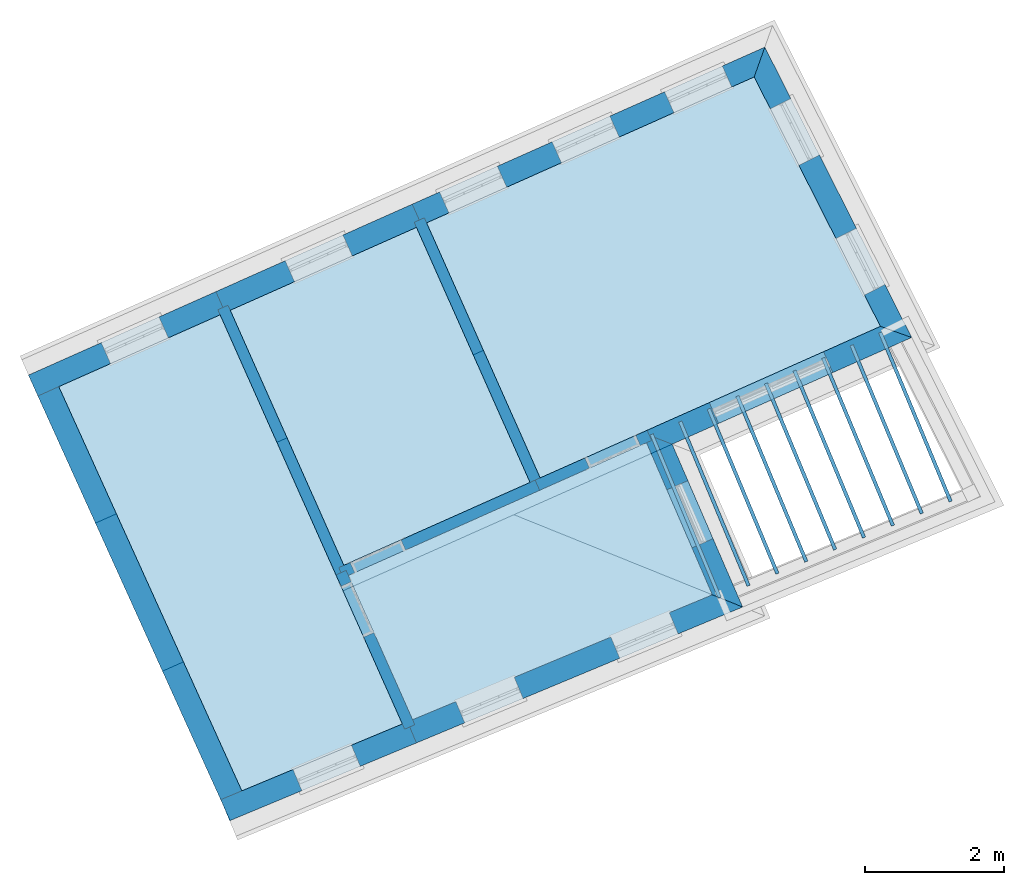
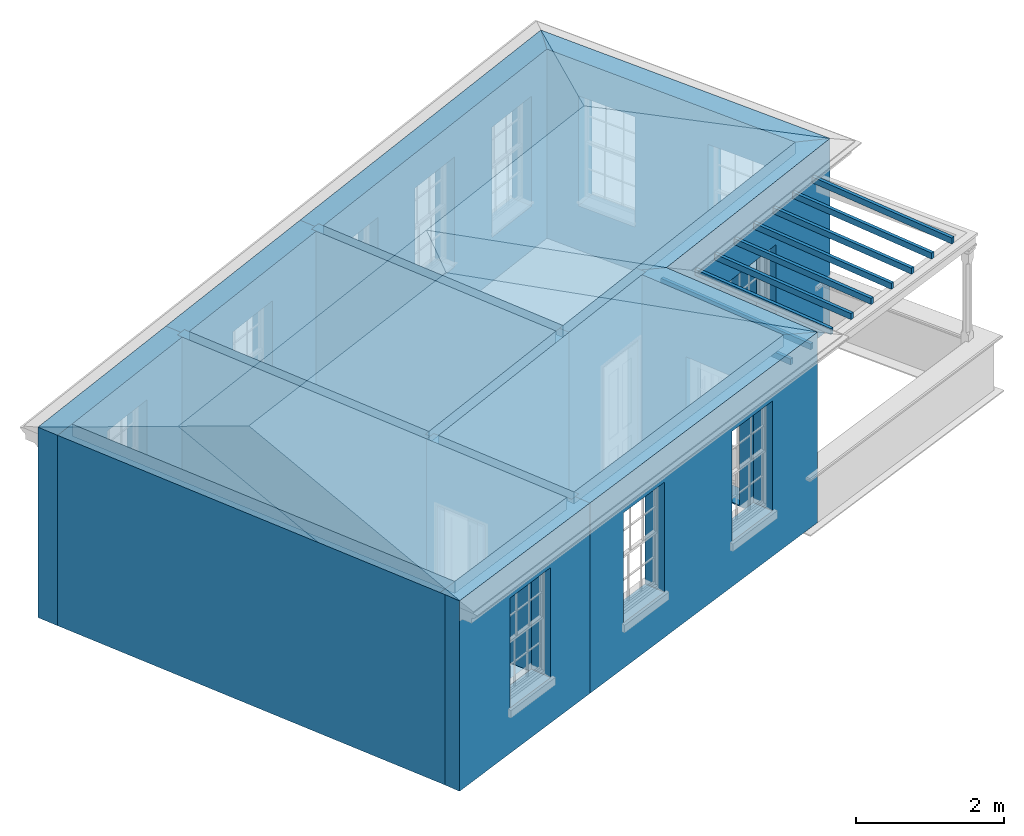
# One storey, part 1 of 10: 16 slabs, 14 walls, 2 roofs, 15 openings.
"""IFC2X3 building model written with IfcOpenShell, lengths in metres."""

from ifc_helpers import new_model, si_unit, frame, origin, place, context, subcontext, project, spatial, polyline, outline, extrude, faceted_brep, material, layer, layer_set, layer_usage, element, save


model = new_model("IFC2X3")

# Units and contexts
model_context = context("Model", 3, world=origin())
body_context = subcontext(model_context, "Body", "Model", "MODEL_VIEW")
ifc_project = project(units=[si_unit("PLANEANGLEUNIT", "RADIAN"), si_unit("MASSUNIT", "GRAM", prefix="KILO"), si_unit("FORCEUNIT", "NEWTON", prefix="KILO"), si_unit("LENGTHUNIT", "METRE")], contexts=[model_context])

# Site, building, storey
site_placement = place(None, origin())
site = spatial("IfcSite", under=ifc_project, at=site_placement, CompositionType="ELEMENT")
building_placement = place(None, origin())
building = spatial("IfcBuilding", under=site, at=building_placement, Name="Building plot-1", CompositionType="ELEMENT")
storey_placement = place(None, frame((0.0, 0.0, 8.45)))
storey = spatial("IfcBuildingStorey", under=building, at=storey_placement, Name="Floor 2", CompositionType="ELEMENT", Elevation=8.45)

# Slabs
slab_1_placement = place(storey_placement, frame((0.0, 0.0, 2.95)))
element("IfcSlab", 1, at=slab_1_placement, inside=storey, Name="Slab", ObjectType="Slab", PredefinedType="FLOOR", context=body_context, shape_type="SweptSolid", body=[
    extrude(outline(polyline([(24.3151590504062, 41.4233427155957), (28.6286616795671, 43.2204467376737), (27.6809340824236, 45.4092594286019), (23.390900849831, 43.4986698452581), (24.3151590504062, 41.4233427155957)])), origin(), (0.0, 0.0, 1.0), 0.2),
])
slab_2_placement = place(storey_placement, frame((0.0, 0.0, 2.95)))
element("IfcSlab", 2, at=slab_2_placement, inside=storey, Name="Slab", ObjectType="Slab", PredefinedType="FLOOR", context=body_context, shape_type="SweptSolid", body=[
    extrude(outline(polyline([(21.8581063270403, 40.3996782574434), (24.1674210791987, 41.3617916919622), (21.5454123248586, 47.2492438116273), (19.2242660267251, 46.2155087102442), (21.8581063270403, 40.3996782574434)])), origin(), (0.0, 0.0, 1.0), 0.2),
])
slab_3_placement = place(storey_placement, frame((0.0, 0.0, 2.95)))
element("IfcSlab", 3, at=slab_3_placement, inside=storey, Name="Slab", ObjectType="Slab", PredefinedType="FLOOR", context=body_context, shape_type="SweptSolid", body=[
    extrude(outline(polyline([(24.5167658048641, 48.572552210313), (26.1510006181193, 44.903045310535), (31.0458649225511, 47.0829996943095), (29.2305507452247, 50.6718619165302), (24.5167658048641, 48.572552210313)])), origin(), (0.0, 0.0, 1.0), 0.2),
])
slab_4_placement = place(storey_placement, frame((0.0, 0.0, 2.65)))
element("IfcSlab", 4, at=slab_4_placement, inside=storey, Name="Slab", ObjectType="Slab", PredefinedType="FLOOR", context=body_context, shape_type="SweptSolid", body=[
    extrude(outline(polyline([(28.7112290415797, 43.1681808719916), (28.7573836046917, 43.1874099204324), (27.7775702899474, 45.5392088465456), (27.7314157268354, 45.5199797981047), (28.7112290415797, 43.1681808719916)])), origin(), (0.0, 0.0, 1.0), 0.1),
])
slab_5_placement = place(storey_placement, frame((0.0, 0.0, 2.65)))
element("IfcSlab", 5, at=slab_5_placement, inside=storey, Name="Slab", ObjectType="Slab", PredefinedType="FLOOR", context=body_context, shape_type="SweptSolid", body=[
    extrude(outline(polyline([(29.1266201095877, 43.3412423079592), (29.1727746726997, 43.3604713564), (28.1887670934018, 45.7223375746439), (28.1426125302898, 45.703108526203), (29.1266201095877, 43.3412423079592)])), origin(), (0.0, 0.0, 1.0), 0.1),
])
slab_6_placement = place(storey_placement, frame((0.0, 0.0, 2.65)))
element("IfcSlab", 6, at=slab_6_placement, inside=storey, Name="Slab", ObjectType="Slab", PredefinedType="FLOOR", context=body_context, shape_type="SweptSolid", body=[
    extrude(outline(polyline([(29.5420111775957, 43.5143037439267), (29.5881657407077, 43.5335327923675), (28.5999638968561, 45.9054663027422), (28.5538093337441, 45.8862372543014), (29.5420111775957, 43.5143037439267)])), origin(), (0.0, 0.0, 1.0), 0.1),
])
slab_7_placement = place(storey_placement, frame((0.0, 0.0, 2.65)))
element("IfcSlab", 7, at=slab_7_placement, inside=storey, Name="Slab", ObjectType="Slab", PredefinedType="FLOOR", context=body_context, shape_type="SweptSolid", body=[
    extrude(outline(polyline([(29.9574022456038, 43.6873651798943), (30.0035568087158, 43.7065942283351), (29.0111607003105, 46.0885950308405), (28.9650061371985, 46.0693659823997), (29.9574022456038, 43.6873651798943)])), origin(), (0.0, 0.0, 1.0), 0.1),
])
slab_8_placement = place(storey_placement, frame((0.0, 0.0, 2.65)))
element("IfcSlab", 8, at=slab_8_placement, inside=storey, Name="Slab", ObjectType="Slab", PredefinedType="FLOOR", context=body_context, shape_type="SweptSolid", body=[
    extrude(outline(polyline([(30.3727933136118, 43.8604266158618), (30.4189478767238, 43.8796556643027), (29.4223575037649, 46.2717237589388), (29.3762029406529, 46.252494710498), (30.3727933136118, 43.8604266158618)])), origin(), (0.0, 0.0, 1.0), 0.1),
])
slab_9_placement = place(storey_placement, frame((0.0, 0.0, 2.65)))
element("IfcSlab", 9, at=slab_9_placement, inside=storey, Name="Slab", ObjectType="Slab", PredefinedType="FLOOR", context=body_context, shape_type="SweptSolid", body=[
    extrude(outline(polyline([(30.7881843816198, 44.0334880518294), (30.8343389447318, 44.0527171002702), (29.8335543072192, 46.4548524870371), (29.7873997441072, 46.4356234385963), (30.7881843816198, 44.0334880518294)])), origin(), (0.0, 0.0, 1.0), 0.1),
])
slab_10_placement = place(storey_placement, frame((0.0, 0.0, 2.65)))
element("IfcSlab", 10, at=slab_10_placement, inside=storey, Name="Slab", ObjectType="Slab", PredefinedType="FLOOR", context=body_context, shape_type="SweptSolid", body=[
    extrude(outline(polyline([(31.2035754496278, 44.206549487797), (31.2497300127398, 44.2257785362378), (30.2447511106736, 46.6379812151354), (30.1985965475616, 46.6187521666946), (31.2035754496278, 44.206549487797)])), origin(), (0.0, 0.0, 1.0), 0.1),
])
slab_11_placement = place(storey_placement, frame((0.0, 0.0, 2.65)))
element("IfcSlab", 11, at=slab_11_placement, inside=storey, Name="Slab", ObjectType="Slab", PredefinedType="FLOOR", context=body_context, shape_type="SweptSolid", body=[
    extrude(outline(polyline([(31.6189665176358, 44.3796109237645), (31.6651210807479, 44.3988399722054), (30.655947914128, 46.8211099432337), (30.609793351016, 46.8018808947929), (31.6189665176358, 44.3796109237645)])), origin(), (0.0, 0.0, 1.0), 0.1),
])
slab_12_placement = place(storey_placement, frame((0.0, 0.0, 2.65)))
element("IfcSlab", 12, at=slab_12_placement, inside=storey, Name="Slab", ObjectType="Slab", PredefinedType="FLOOR", context=body_context, shape_type="SweptSolid", body=[
    extrude(outline(polyline([(32.0343575856439, 44.5526723597321), (32.0805121487559, 44.5719014081729), (31.0671447175823, 47.004238671332), (31.0209901544703, 46.9850096228912), (32.0343575856439, 44.5526723597321)])), origin(), (0.0, 0.0, 1.0), 0.1),
])
slab_13_placement = place(storey_placement, frame((0.0, 0.0, 2.95)))
element("IfcSlab", 13, at=slab_13_placement, inside=storey, Name="Slab", ObjectType="Slab", PredefinedType="FLOOR", context=body_context, shape_type="SweptSolid", body=[
    extrude(outline(polyline([(24.3706054157099, 48.50745888775), (21.6915727140128, 47.3143371341903), (23.325807527268, 43.6448302344123), (26.0048402289651, 44.837951987972), (24.3706054157099, 48.50745888775)])), origin(), (0.0, 0.0, 1.0), 0.2),
])
slab_14_placement = place(storey_placement, origin())
element("IfcSlab", 14, at=slab_14_placement, inside=storey, Name="Slab", ObjectType="Slab", PredefinedType="FLOOR", context=body_context, shape_type="SweptSolid", body=[
    extrude(outline(polyline([(21.8581063270403, 40.3996782574434), (24.1674210791987, 41.3617916919622), (21.5454123248586, 47.2492438116273), (19.2242660267251, 46.2155087102442), (21.8581063270403, 40.3996782574434)])), origin(), (0.0, 0.0, 1.0), 0.02),
])
slab_15_placement = place(storey_placement, origin())
element("IfcSlab", 15, at=slab_15_placement, inside=storey, Name="Slab", ObjectType="Slab", PredefinedType="FLOOR", context=body_context, shape_type="SweptSolid", body=[
    extrude(outline(polyline([(24.5167658048641, 48.572552210313), (26.1510006181193, 44.903045310535), (31.0458649225511, 47.0829996943095), (29.2305507452247, 50.6718619165302), (24.5167658048641, 48.572552210313)])), origin(), (0.0, 0.0, 1.0), 0.02),
])
slab_16_placement = place(storey_placement, origin())
element("IfcSlab", 16, at=slab_16_placement, inside=storey, Name="Slab", ObjectType="Slab", PredefinedType="FLOOR", context=body_context, shape_type="SweptSolid", body=[
    extrude(outline(polyline([(24.3706054157099, 48.50745888775), (21.6915727140128, 47.3143371341903), (23.325807527268, 43.6448302344123), (26.0048402289651, 44.837951987972), (24.3706054157099, 48.50745888775)])), origin(), (0.0, 0.0, 1.0), 0.02),
])

# Wall, opening
ifc_material_1 = material(Name="Masonry")
ifc_layer_1 = layer(ifc_material_1, 0.33, ventilated=False)
ifc_layer_set_1 = layer_set([ifc_layer_1], Name="My Wall")
ifc_layer_usage_1 = layer_usage(ifc_layer_set_1, "AXIS2", "NEGATIVE", 0.08)
wall_1_placement = place(storey_placement, origin())
wall_1 = element("IfcWallStandardCase", 17, at=wall_1_placement, inside=storey, material=ifc_layer_usage_1, Name="exterior", context=body_context, shape_type="SweptSolid", body=[
    extrude(outline(polyline([(21.5557040167118, 40.2736905266135), (21.6826157364214, 39.9690704100743), (24.3699915253352, 41.0886927342715), (24.2430798056257, 41.3933128508107), (21.5557040167118, 40.2736905266135)])), origin(), (0.0, 0.0, 1.0), 3.15),
])
opening_1_placement = place(storey_placement, frame((0.0, 0.0, 0.75)))
element("IfcOpeningElement", 18, at=opening_1_placement, cuts=wall_1, Name="Opening", ObjectType="Opening", context=body_context, shape_type="SweptSolid", body=[
    extrude(outline(polyline([(22.7216835143391, 40.4019698524633), (23.5616965629775, 40.7519385340866), (23.434784843268, 41.0565586506259), (22.5947717946295, 40.7065899690026), (22.7216835143391, 40.4019698524633)])), origin(), (0.0, 0.0, 1.0), 1.82),
])

# Wall, openings
wall_2_placement = place(storey_placement, origin())
wall_2 = element("IfcWallStandardCase", 19, at=wall_2_placement, inside=storey, material=ifc_layer_usage_1, Name="exterior", context=body_context, shape_type="SweptSolid", body=[
    extrude(outline(polyline([(24.2430798056257, 41.3933128508107), (24.3699915253352, 41.0886927342715), (29.0644458342875, 43.0445099541443), (28.6286616795671, 43.2204467376737), (24.2430798056257, 41.3933128508107)])), origin(), (0.0, 0.0, 1.0), 3.15),
])
opening_2_placement = place(storey_placement, frame((0.0, 0.0, 0.75)))
element("IfcOpeningElement", 20, at=opening_2_placement, cuts=wall_2, Name="Opening", ObjectType="Opening", context=body_context, shape_type="SweptSolid", body=[
    extrude(outline(polyline([(25.0651000110172, 41.378290855055), (25.9051130596556, 41.7282595366783), (25.7782013399461, 42.0328796532175), (24.9381882913076, 41.6829109715942), (25.0651000110172, 41.378290855055)])), origin(), (0.0, 0.0, 1.0), 1.82),
])
opening_3_placement = place(storey_placement, frame((0.0, 0.0, 0.75)))
element("IfcOpeningElement", 21, at=opening_3_placement, cuts=wall_2, Name="Opening", ObjectType="Opening", context=body_context, shape_type="SweptSolid", body=[
    extrude(outline(polyline([(27.2953300310195, 42.3074557782452), (28.135343079658, 42.6574244598685), (28.0084313599484, 42.9620445764077), (27.16841831131, 42.6120758947844), (27.2953300310195, 42.3074557782452)])), origin(), (0.0, 0.0, 1.0), 1.82),
])

# Wall, opening
wall_3_placement = place(storey_placement, origin())
wall_3 = element("IfcWallStandardCase", 22, at=wall_3_placement, inside=storey, material=ifc_layer_usage_1, Name="exterior", context=body_context, shape_type="SweptSolid", body=[
    extrude(outline(polyline([(28.6286616795671, 43.2204467376737), (29.0644458342875, 43.0445099541443), (28.0499575041078, 45.3875090802526), (27.617356280873, 45.5560947632642), (28.6286616795671, 43.2204467376737)])), origin(), (0.0, 0.0, 1.0), 3.15),
])
opening_4_placement = place(storey_placement, frame((0.0, 0.0, 0.0199999999999996)))
element("IfcOpeningElement", 23, at=opening_4_placement, cuts=wall_3, Name="Opening", ObjectType="Opening", context=body_context, shape_type="SweptSolid", body=[
    extrude(outline(polyline([(28.6384753465714, 44.0283048887692), (28.2768960371276, 44.8633859644631), (27.9740644382496, 44.7322637973022), (28.3356437476933, 43.8971827216083), (28.6384753465714, 44.0283048887692)])), origin(), (0.0, 0.0, 1.0), 2.08),
])

wall_4_placement = place(storey_placement, origin())
wall_4 = element("IfcWallStandardCase", 24, at=wall_4_placement, inside=storey, material=ifc_layer_usage_1, Name="exterior", context=body_context, shape_type="SweptSolid", body=[
    extrude(outline(polyline([(27.617356280873, 45.5560947632642), (28.0499575041078, 45.3875090802526), (31.4968184786281, 46.9225873223324), (31.0458649225511, 47.0829996943095), (27.617356280873, 45.5560947632642)])), origin(), (0.0, 0.0, 1.0), 3.15),
])
opening_5_placement = place(storey_placement, frame((0.0, 0.0, 0.0199999999999996)))
element("IfcOpeningElement", 25, at=opening_5_placement, cuts=wall_4, Name="Opening", ObjectType="Opening", context=body_context, shape_type="SweptSolid", body=[
    extrude(outline(polyline([(28.7182642782321, 45.6851431291963), (30.3625686562166, 46.4174430080309), (30.2283136784303, 46.7188988106614), (28.5840093004458, 45.9865989318268), (28.7182642782321, 45.6851431291963)])), origin(), (0.0, 0.0, 1.0), 2.08),
])

# Wall, openings
wall_5_placement = place(storey_placement, origin())
wall_5 = element("IfcWallStandardCase", 26, at=wall_5_placement, inside=storey, material=ifc_layer_usage_1, Name="exterior", context=body_context, shape_type="SweptSolid", body=[
    extrude(outline(polyline([(31.0458649225511, 47.0829996943095), (31.4968184786281, 46.9225873223324), (29.383242432719, 51.1011109738831), (29.2305507452247, 50.6718619165302), (31.0458649225511, 47.0829996943095)])), origin(), (0.0, 0.0, 1.0), 3.15),
])
opening_6_placement = place(storey_placement, frame((0.0, 0.0, 0.75)))
element("IfcOpeningElement", 27, at=opening_6_placement, cuts=wall_5, Name="Opening", ObjectType="Opening", context=body_context, shape_type="SweptSolid", body=[
    extrude(outline(polyline([(31.111737146863, 47.6838901652868), (30.7009970967879, 48.4959200977797), (30.4065247036861, 48.3469704092909), (30.8172647537612, 47.5349404767981), (31.111737146863, 47.6838901652868)])), origin(), (0.0, 0.0, 1.0), 1.82),
])
opening_7_placement = place(storey_placement, frame((0.0, 0.0, 0.75)))
element("IfcOpeningElement", 28, at=opening_7_placement, cuts=wall_5, Name="Opening", ObjectType="Opening", context=body_context, shape_type="SweptSolid", body=[
    extrude(outline(polyline([(30.1679271044322, 49.5497953890432), (29.7571870543571, 50.3618253215361), (29.4627146612553, 50.2128756330473), (29.8734547113304, 49.4008457005545), (30.1679271044322, 49.5497953890432)])), origin(), (0.0, 0.0, 1.0), 1.82),
])

wall_6_placement = place(storey_placement, origin())
wall_6 = element("IfcWallStandardCase", 29, at=wall_6_placement, inside=storey, material=ifc_layer_usage_1, Name="exterior", context=body_context, shape_type="SweptSolid", body=[
    extrude(outline(polyline([(29.2305507452247, 50.6718619165302), (29.383242432719, 51.1011109738831), (24.3094306325007, 48.841461351662), (24.443685610287, 48.5400055490315), (29.2305507452247, 50.6718619165302)])), origin(), (0.0, 0.0, 1.0), 3.15),
])
opening_8_placement = place(storey_placement, frame((0.0, 0.0, 0.75)))
element("IfcOpeningElement", 30, at=opening_8_placement, cuts=wall_6, Name="Opening", ObjectType="Opening", context=body_context, shape_type="SweptSolid", body=[
    extrude(outline(polyline([(28.7720975415616, 50.8289342797521), (27.9408103282473, 50.4587160076747), (28.0750653060336, 50.1572602050442), (28.906352519348, 50.5274784771217), (28.7720975415616, 50.8289342797521)])), origin(), (0.0, 0.0, 1.0), 1.82),
])
opening_9_placement = place(storey_placement, frame((0.0, 0.0, 0.75)))
element("IfcOpeningElement", 31, at=opening_9_placement, cuts=wall_6, Name="Opening", ObjectType="Opening", context=body_context, shape_type="SweptSolid", body=[
    extrude(outline(polyline([(27.1532882206001, 50.1079887629316), (26.3220010072858, 49.7377704908541), (26.4562559850721, 49.4363146882236), (27.2875431983865, 49.8065329603011), (27.1532882206001, 50.1079887629316)])), origin(), (0.0, 0.0, 1.0), 1.82),
])
opening_10_placement = place(storey_placement, frame((0.0, 0.0, 0.75)))
element("IfcOpeningElement", 32, at=opening_10_placement, cuts=wall_6, Name="Opening", ObjectType="Opening", context=body_context, shape_type="SweptSolid", body=[
    extrude(outline(polyline([(25.5344788996386, 49.387043246111), (24.7031916863243, 49.0168249740335), (24.8374466641106, 48.7153691714031), (25.668733877425, 49.0855874434805), (25.5344788996386, 49.387043246111)])), origin(), (0.0, 0.0, 1.0), 1.82),
])

# Wall, opening
wall_7_placement = place(storey_placement, origin())
wall_7 = element("IfcWallStandardCase", 33, at=wall_7_placement, inside=storey, material=ifc_layer_usage_1, Name="exterior", context=body_context, shape_type="SweptSolid", body=[
    extrude(outline(polyline([(24.443685610287, 48.5400055490315), (24.3094306325007, 48.841461351662), (21.4842375416494, 47.5832462755393), (21.6184925194357, 47.2817904729088), (24.443685610287, 48.5400055490315)])), origin(), (0.0, 0.0, 1.0), 3.15),
])
opening_11_placement = place(storey_placement, frame((0.0, 0.0, 0.75)))
element("IfcOpeningElement", 34, at=opening_11_placement, cuts=wall_7, Name="Opening", ObjectType="Opening", context=body_context, shape_type="SweptSolid", body=[
    extrude(outline(polyline([(23.3124776937322, 48.3974629496394), (22.4811904804179, 48.0272446775619), (22.6154454582042, 47.7257888749314), (23.4467326715186, 48.0960071470089), (23.3124776937322, 48.3974629496394)])), origin(), (0.0, 0.0, 1.0), 1.82),
])

wall_8_placement = place(storey_placement, origin())
wall_8 = element("IfcWallStandardCase", 35, at=wall_8_placement, inside=storey, material=ifc_layer_usage_1, Name="exterior", context=body_context, shape_type="SweptSolid", body=[
    extrude(outline(polyline([(21.6184925194357, 47.2817904729088), (21.4842375416494, 47.5832462755393), (18.7880965575994, 46.3825052555824), (18.9223515353857, 46.0810494529519), (21.6184925194357, 47.2817904729088)])), origin(), (0.0, 0.0, 1.0), 3.15),
])
opening_12_placement = place(storey_placement, frame((0.0, 0.0, 0.75)))
element("IfcOpeningElement", 36, at=opening_12_placement, cuts=wall_8, Name="Opening", ObjectType="Opening", context=body_context, shape_type="SweptSolid", body=[
    extrude(outline(polyline([(20.6659984603083, 47.218839059852), (19.8347112469939, 46.8486207877745), (19.9689662247802, 46.547164985144), (20.8002534380946, 46.9173832572215), (20.6659984603083, 47.218839059852)])), origin(), (0.0, 0.0, 1.0), 1.82),
])

# Walls
wall_9_placement = place(storey_placement, origin())
element("IfcWallStandardCase", 37, at=wall_9_placement, inside=storey, material=ifc_layer_usage_1, Name="party", context=body_context, shape_type="SweptSolid", body=[
    extrude(outline(polyline([(19.1910556078216, 46.2888412374996), (18.8904457144576, 46.1527027344532), (21.5895085420772, 40.1928532382579), (21.8901184354412, 40.3289917413043), (19.1910556078216, 46.2888412374996)])), origin(), (0.0, 0.0, 1.0), 3.15),
])
ifc_material_2 = material(Name="Masonry")
ifc_layer_2 = layer(ifc_material_2, 0.16, ventilated=False)
ifc_layer_set_2 = layer_set([ifc_layer_2], Name="My Wall")
ifc_layer_usage_2 = layer_usage(ifc_layer_set_2, "AXIS2", "NEGATIVE", 0.08)
wall_10_placement = place(storey_placement, origin())
element("IfcWallStandardCase", 38, at=wall_10_placement, inside=storey, material=ifc_layer_usage_2, Name="interior", context=body_context, shape_type="SweptSolid", body=[
    extrude(outline(polyline([(23.2121937993953, 43.5066567172722), (23.3583541885495, 43.5717500398352), (21.6590260527313, 47.3874173287674), (21.5128656635771, 47.3223240062044), (23.2121937993953, 43.5066567172722)])), origin(), (0.0, 0.0, 1.0), 3.15),
])

# Wall, opening
wall_11_placement = place(storey_placement, origin())
wall_11 = element("IfcWallStandardCase", 39, at=wall_11_placement, inside=storey, material=ifc_layer_usage_2, Name="interior", context=body_context, shape_type="SweptSolid", body=[
    extrude(outline(polyline([(23.2527273326909, 43.6122835731308), (23.3178206552539, 43.4661231839766), (26.1430137461052, 44.7243382600993), (26.0779204235422, 44.8704986492535), (23.2527273326909, 43.6122835731308)])), origin(), (0.0, 0.0, 1.0), 3.15),
])
opening_13_placement = place(storey_placement, frame((0.0, 0.0, 0.0199999999999996)))
element("IfcOpeningElement", 40, at=opening_13_placement, cuts=wall_11, Name="Opening", ObjectType="Opening", context=body_context, shape_type="SweptSolid", body=[
    extrude(outline(polyline([(23.4822510930524, 43.5393531718601), (24.2130530388233, 43.8648197846754), (24.1479597162602, 44.0109801738296), (23.4171577704893, 43.6855135610142), (23.4822510930524, 43.5393531718601)])), origin(), (0.0, 0.0, 1.0), 2.1),
])

wall_12_placement = place(storey_placement, origin())
wall_12 = element("IfcWallStandardCase", 41, at=wall_12_placement, inside=storey, material=ifc_layer_usage_2, Name="interior", context=body_context, shape_type="SweptSolid", body=[
    extrude(outline(polyline([(23.3583541885495, 43.5717500398352), (23.2121937993953, 43.5066567172722), (24.2007660885539, 41.28691888855), (24.3469264777081, 41.352012211113), (23.3583541885495, 43.5717500398352)])), origin(), (0.0, 0.0, 1.0), 3.15),
])
opening_14_placement = place(storey_placement, frame((0.0, 0.0, 0.0199999999999996)))
element("IfcOpeningElement", 42, at=opening_14_placement, cuts=wall_12, Name="Opening", ObjectType="Opening", context=body_context, shape_type="SweptSolid", body=[
    extrude(outline(polyline([(23.2854237872788, 43.3422262794737), (23.6108904000941, 42.6114243337028), (23.7570507892483, 42.6765176562659), (23.4315841764329, 43.4073196020368), (23.2854237872788, 43.3422262794737)])), origin(), (0.0, 0.0, 1.0), 2.1),
])

wall_13_placement = place(storey_placement, origin())
wall_13 = element("IfcWallStandardCase", 43, at=wall_13_placement, inside=storey, material=ifc_layer_usage_2, Name="interior", context=body_context, shape_type="SweptSolid", body=[
    extrude(outline(polyline([(27.754775965969, 45.4421453121994), (27.689682643406, 45.5883057013536), (26.0779204235422, 44.8704986492535), (26.1430137461052, 44.7243382600993), (27.754775965969, 45.4421453121994)])), origin(), (0.0, 0.0, 1.0), 3.15),
])
opening_15_placement = place(storey_placement, frame((0.0, 0.0, 0.0199999999999996)))
element("IfcOpeningElement", 44, at=opening_15_placement, cuts=wall_13, Name="Opening", ObjectType="Opening", context=body_context, shape_type="SweptSolid", body=[
    extrude(outline(polyline([(27.5252522056075, 45.5150757134701), (26.7944502598366, 45.1896091006548), (26.8595435823997, 45.0434487115006), (27.5903455281706, 45.368915324316), (27.5252522056075, 45.5150757134701)])), origin(), (0.0, 0.0, 1.0), 2.1),
])

# Wall
wall_14_placement = place(storey_placement, origin())
element("IfcWallStandardCase", 45, at=wall_14_placement, inside=storey, material=ifc_layer_usage_2, Name="interior", context=body_context, shape_type="SweptSolid", body=[
    extrude(outline(polyline([(26.0373868902466, 44.7648717933949), (26.1835472794008, 44.8299651159579), (24.4842191435826, 48.6456324048901), (24.3380587544284, 48.5805390823271), (26.0373868902466, 44.7648717933949)])), origin(), (0.0, 0.0, 1.0), 3.15),
])

# Roofs
roof_1_placement = place(building_placement, origin())
element("IfcRoof", 46, at=roof_1_placement, inside=storey, Name="Roof", ShapeType="FREEFORM", context=body_context, shape_type="Brep", held_by="IfcProductRepresentation", body=[
    faceted_brep([(26.191513, 49.679657, 11.6), (18.786663, 46.381867, 11.6), (20.237782, 43.177626, 13.056974), (24.347854, 44.948714, 13.079432), (21.689546, 39.971958, 11.6), (29.064446, 43.04451, 11.6)], [[[0, 1, 2, 3]], [[4, 5, 3, 2]], [[5, 4, 1, 0]], [[5, 0, 3]], [[1, 4, 2]]]),
])
roof_2_placement = place(building_placement, origin())
element("IfcRoof", 47, at=roof_2_placement, inside=storey, Name="Roof", ShapeType="FREEFORM", context=body_context, shape_type="Brep", held_by="IfcProductRepresentation", body=[
    faceted_brep([(29.383242, 51.101111, 11.6), (18.786663, 46.381867, 11.6), (19.751402, 44.25161, 12.568631), (28.301222, 48.059319, 12.568631), (20.71614, 42.121354, 11.6), (31.496818, 46.922587, 11.6)], [[[0, 1, 2, 3]], [[4, 5, 3, 2]], [[5, 4, 1, 0]], [[5, 0, 3]], [[1, 4, 2]]]),
])

save(model, "model.ifc")
